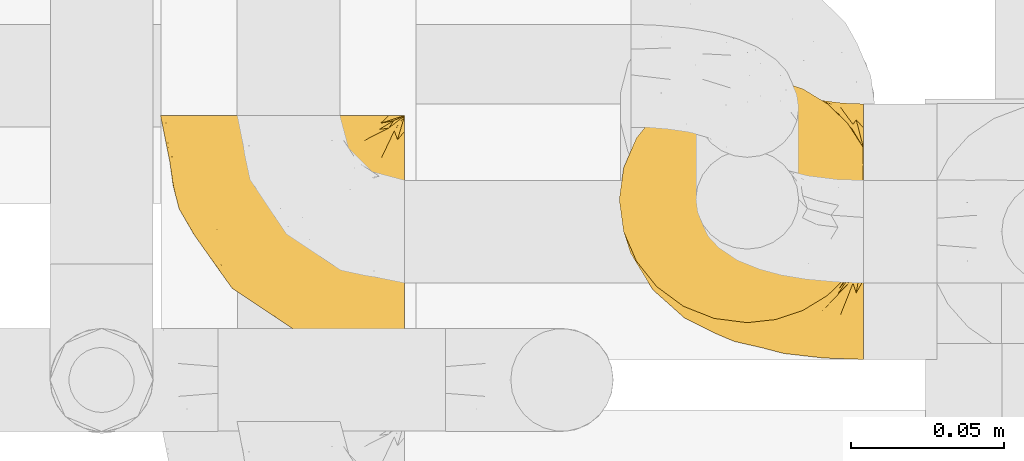
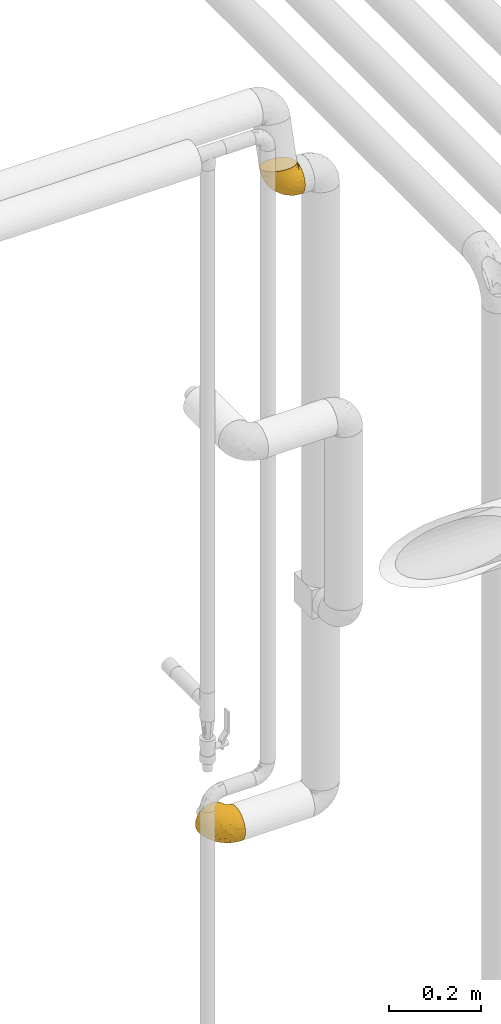
# One storey, part 354 of 827: 2 coverings.
"""IFC2X3 building model written with IfcOpenShell, lengths in millimetres."""

from ifc_helpers import new_model, entity, si_unit, converted_unit, derived_unit, direction, frame, origin, place, context, subcontext, project, spatial, faceted_brep, element, save


model = new_model("IFC2X3")

# Units and contexts
model_context = context("Model", 3, precision=0.01, world=origin(), true_north=direction((6.12303176911189e-17, 1.0)))
body_context = subcontext(model_context, "Body", "Model", "MODEL_VIEW")
ifc_project = project(units=[si_unit("LENGTHUNIT", "METRE", prefix="MILLI"), si_unit("AREAUNIT", "SQUARE_METRE"), si_unit("VOLUMEUNIT", "CUBIC_METRE"), converted_unit("PLANEANGLEUNIT", "DEGREE", entity("IfcRatioMeasure", 0.0174532925199433), si_unit("PLANEANGLEUNIT", "RADIAN"), dimensions=[0, 0, 0, 0, 0, 0, 0]), si_unit("MASSUNIT", "GRAM", prefix="KILO"), derived_unit("MASSDENSITYUNIT", [(si_unit("MASSUNIT", "GRAM", prefix="KILO"), 1), (si_unit("LENGTHUNIT", "METRE"), -3)]), derived_unit("MOMENTOFINERTIAUNIT", [(si_unit("LENGTHUNIT", "METRE"), 4)]), si_unit("TIMEUNIT", "SECOND"), si_unit("FREQUENCYUNIT", "HERTZ"), si_unit("THERMODYNAMICTEMPERATUREUNIT", "DEGREE_CELSIUS"), derived_unit("THERMALTRANSMITTANCEUNIT", [(si_unit("MASSUNIT", "GRAM", prefix="KILO"), 1), (si_unit("THERMODYNAMICTEMPERATUREUNIT", "KELVIN"), -1), (si_unit("TIMEUNIT", "SECOND"), -3)]), derived_unit("VOLUMETRICFLOWRATEUNIT", [(si_unit("LENGTHUNIT", "METRE"), 3), (si_unit("TIMEUNIT", "SECOND"), -1)]), derived_unit("MASSFLOWRATEUNIT", [(si_unit("MASSUNIT", "GRAM", prefix="KILO"), 1), (si_unit("TIMEUNIT", "SECOND"), -1)]), derived_unit("ROTATIONALFREQUENCYUNIT", [(si_unit("TIMEUNIT", "SECOND"), -1)]), si_unit("ELECTRICCURRENTUNIT", "AMPERE"), si_unit("ELECTRICVOLTAGEUNIT", "VOLT"), si_unit("POWERUNIT", "WATT"), si_unit("FORCEUNIT", "NEWTON", prefix="KILO"), si_unit("ILLUMINANCEUNIT", "LUX"), si_unit("LUMINOUSFLUXUNIT", "LUMEN"), si_unit("LUMINOUSINTENSITYUNIT", "CANDELA"), derived_unit("USERDEFINED", [(si_unit("MASSUNIT", "GRAM", prefix="KILO"), -1), (si_unit("LENGTHUNIT", "METRE"), -2), (si_unit("TIMEUNIT", "SECOND"), 3), (si_unit("LUMINOUSFLUXUNIT", "LUMEN"), 1)]), derived_unit("LINEARVELOCITYUNIT", [(si_unit("LENGTHUNIT", "METRE"), 1), (si_unit("TIMEUNIT", "SECOND"), -1)]), si_unit("PRESSUREUNIT", "PASCAL"), derived_unit("USERDEFINED", [(si_unit("LENGTHUNIT", "METRE"), -2), (si_unit("MASSUNIT", "GRAM", prefix="KILO"), 1), (si_unit("TIMEUNIT", "SECOND"), -2)]), derived_unit("LINEARFORCEUNIT", [(si_unit("MASSUNIT", "GRAM", prefix="KILO"), 1), (si_unit("LENGTHUNIT", "METRE"), 1), (si_unit("TIMEUNIT", "SECOND"), -2), (si_unit("LENGTHUNIT", "METRE"), -1)]), derived_unit("PLANARFORCEUNIT", [(si_unit("MASSUNIT", "GRAM", prefix="KILO"), 1), (si_unit("LENGTHUNIT", "METRE"), 1), (si_unit("TIMEUNIT", "SECOND"), -2), (si_unit("LENGTHUNIT", "METRE"), -2)])], contexts=[model_context])

# Site, building, storey
site_placement = place(None, origin())
site = spatial("IfcSite", under=ifc_project, at=site_placement, CompositionType="ELEMENT")
building_placement = place(site_placement, origin())
building = spatial("IfcBuilding", under=site, at=building_placement, CompositionType="ELEMENT")
storey_placement = place(building_placement, frame((0.0, 0.0, 28200.0)))
storey = spatial("IfcBuildingStorey", under=building, at=storey_placement, Name="08", CompositionType="ELEMENT", Elevation=28200.0)

# Coverings
covering_1_placement = place(storey_placement, frame((43432.77, 15237.95, 2778.82)))
element("IfcCovering", 1, at=covering_1_placement, inside=storey, Name=":ADSK_", ObjectType=":ADSK_", PredefinedType="INSULATION", context=body_context, shape_type="Brep", body=[
    faceted_brep([(81.45, 2.13, 36.31), (81.45, 4.74, 27.31), (81.45, 9.29, 19.12), (81.45, 15.54, 12.14), (81.45, 23.19, 6.73), (81.45, 31.85, 3.15), (81.45, 41.09, 1.6), (81.45, 50.45, 2.13), (81.45, 59.45, 4.74), (81.45, 67.65, 9.29), (81.45, 74.63, 15.54), (81.45, 80.04, 23.19), (81.45, 83.61, 31.85), (81.45, 85.17, 41.15), (81.45, 84.61, 50.56), (81.45, 81.96, 59.61), (81.45, 77.35, 67.83), (81.45, 71.03, 74.8), (81.45, 70.14, 75.06), (81.45, 69.26, 75.31), (81.45, 68.49, 75.53), (81.45, 67.22, 75.89), (81.45, 65.95, 76.26), (81.45, 64.68, 76.62), (81.45, 63.41, 76.99), (81.45, 62.14, 77.35), (81.45, 60.87, 77.71), (81.45, 59.6, 78.08), (81.45, 58.33, 78.44), (81.45, 57.07, 78.81), (81.45, 55.8, 79.17), (81.45, 54.53, 79.53), (81.45, 53.26, 79.9), (81.45, 51.99, 80.26), (81.45, 50.72, 80.63), (81.45, 49.84, 80.88), (81.45, 48.95, 81.13), (81.45, 48.07, 81.39), (81.45, 47.19, 81.64), (81.45, 46.3, 81.89), (81.45, 45.42, 82.15), (81.45, 44.54, 82.4), (81.45, 43.65, 82.65), (81.45, 42.77, 82.9), (81.45, 41.89, 83.16), (81.45, 41.0, 83.41), (81.45, 40.12, 83.66), (81.45, 39.24, 83.92), (81.45, 38.36, 84.17), (81.45, 37.47, 84.42), (81.45, 36.59, 84.68), (81.45, 27.52, 82.11), (81.45, 19.25, 77.57), (81.45, 12.21, 71.3), (81.45, 6.75, 63.62), (81.45, 3.15, 54.92), (81.45, 1.6, 45.67), (76.3, 78.78, 72.77), (69.67, 85.21, 70.92), (61.7, 90.06, 69.53), (52.81, 93.07, 68.67), (43.45, 94.09, 68.38), (32.61, 92.71, 68.77), (22.52, 88.7, 69.92), (13.85, 82.3, 71.75), (7.2, 73.97, 74.14), (3.02, 64.27, 76.92), (1.6, 53.86, 79.91), (3.02, 43.44, 82.9), (7.2, 33.74, 85.68), (13.85, 25.41, 88.07), (22.52, 19.02, 89.9), (32.61, 15.0, 91.05), (43.45, 13.63, 91.45), (52.81, 14.65, 91.15), (61.7, 17.66, 90.29), (69.67, 22.5, 88.9), (76.3, 28.94, 87.06), (81.27, 36.64, 84.85), (81.27, 37.52, 84.59), (81.27, 38.79, 84.23), (81.27, 39.87, 83.92), (81.27, 40.94, 83.61), (81.27, 42.02, 83.3), (81.27, 43.1, 83.0), (81.27, 44.17, 82.69), (81.27, 45.25, 82.38), (81.27, 46.32, 82.07), (81.27, 47.4, 81.76), (81.27, 48.48, 81.45), (81.27, 49.55, 81.14), (81.27, 50.63, 80.84), (81.27, 51.7, 80.53), (81.27, 52.78, 80.22), (81.27, 53.86, 79.91), (81.27, 55.13, 79.55), (81.27, 56.4, 79.18), (81.27, 57.66, 78.82), (81.27, 58.93, 78.45), (81.27, 60.2, 78.09), (81.27, 61.47, 77.73), (81.27, 62.74, 77.36), (81.27, 64.01, 77.0), (81.27, 64.89, 76.75), (81.27, 65.78, 76.49), (81.27, 66.66, 76.24), (81.27, 67.54, 75.99), (81.27, 68.43, 75.73), (81.27, 69.31, 75.48), (81.27, 70.19, 75.23), (81.27, 71.08, 74.97), (81.31, 43.6, 82.73), (81.33, 42.56, 83.01), (81.31, 60.81, 77.8), (81.32, 61.82, 77.5), (81.31, 53.29, 79.95), (81.32, 52.26, 80.24), (81.32, 36.6, 84.73), (81.32, 37.93, 84.35), (81.32, 51.19, 80.54), (81.32, 69.88, 75.19), (81.32, 50.06, 80.86), (81.32, 67.07, 76.0), (81.3, 67.99, 75.75), (81.32, 57.35, 78.78), (81.33, 44.67, 82.41), (81.31, 45.75, 82.11), (81.33, 56.36, 79.05), (81.32, 55.33, 79.35), (81.32, 54.31, 79.65), (81.32, 68.89, 75.47), (81.31, 49.06, 81.16), (81.32, 59.81, 78.08), (81.31, 63.34, 77.07), (81.32, 64.35, 76.77), (81.32, 66.08, 76.28), (81.32, 46.86, 81.79), (81.33, 47.9, 81.48), (81.32, 41.44, 83.34), (81.31, 40.37, 83.65), (81.33, 38.99, 84.04), (81.32, 71.04, 74.85), (81.36, 36.6, 84.71), (81.4, 36.59, 84.7), (81.4, 71.03, 74.82), (81.36, 71.04, 74.84), (81.29, 36.62, 84.8), (81.3, 36.61, 84.76), (81.3, 71.05, 74.89), (81.29, 71.06, 74.93), (81.35, 65.21, 76.5), (81.31, 58.38, 78.49), (58.5, 89.77, 61.93), (71.95, 84.31, 34.29), (74.57, 85.43, 46.83), (73.93, 84.07, 57.01), (78.18, 83.64, 55.49), (78.04, 78.45, 67.67), (76.23, 79.36, 68.32), (45.99, 91.47, 59.24), (74.01, 82.71, 62.07), (73.57, 81.47, 69.35), (66.66, 86.47, 65.33), (79.09, 79.98, 64.18), (73.14, 82.04, 67.1), (60.34, 88.1, 53.25), (48.54, 88.85, 50.11), (45.36, 92.12, 61.51), (67.22, 86.39, 47.63), (62.45, 85.01, 36.74), (68.67, 85.8, 56.47), (55.49, 86.93, 43.43), (77.84, 76.83, 71.54), (68.16, 85.59, 62.27), (74.31, 84.14, 33.69), (38.78, 46.66, 13.69), (62.1, 46.46, 3.96), (50.89, 33.52, 9.0), (36.91, 89.69, 56.13), (40.37, 87.12, 47.37), (27.86, 77.24, 39.14), (15.77, 70.76, 46.45), (20.13, 81.24, 54.97), (31.54, 85.33, 49.38), (28.25, 88.44, 60.24), (57.26, 72.71, 17.09), (69.99, 71.62, 13.27), (64.58, 64.27, 8.84), (50.64, 83.78, 35.42), (51.97, 56.73, 9.12), (5.72, 54.94, 55.69), (7.42, 63.76, 56.33), (66.14, 32.69, 6.08), (11.35, 74.9, 60.86), (21.64, 47.01, 27.97), (28.57, 51.69, 21.66), (55.38, 80.52, 27.64), (68.51, 78.0, 20.79), (67.48, 55.39, 4.47), (40.78, 75.79, 27.54), (41.53, 82.05, 36.06), (46.11, 69.17, 18.35), (40.32, 61.91, 16.81), (38.36, 54.55, 15.17), (11.84, 58.75, 43.77), (12.56, 50.44, 40.34), (7.67, 45.43, 50.54), (19.39, 55.75, 31.87), (24.98, 38.29, 25.64), (37.94, 35.91, 17.32), (4.64, 49.64, 65.2), (28.09, 61.32, 25.25), (23.73, 68.86, 34.4), (34.03, 69.03, 25.45), (16.33, 41.86, 38.09), (29.29, 12.82, 77.06), (5.77, 39.87, 60.03), (21.44, 26.91, 36.72), (38.8, 24.87, 19.93), (64.58, 7.37, 25.14), (67.49, 12.59, 16.74), (22.9, 15.18, 65.48), (12.54, 24.42, 69.69), (20.04, 19.94, 50.76), (57.26, 4.58, 36.61), (69.99, 3.49, 32.8), (68.51, 2.05, 42.55), (34.54, 17.83, 30.43), (38.81, 9.53, 74.25), (48.54, 8.39, 73.18), (45.99, 11.01, 82.31), (74.31, 3.68, 56.76), (5.36, 36.27, 70.79), (18.96, 18.86, 78.33), (12.79, 35.57, 44.23), (62.11, 19.89, 11.57), (33.14, 10.06, 53.04), (33.44, 10.0, 68.12), (51.98, 13.92, 21.38), (43.42, 7.37, 67.13), (48.62, 5.33, 59.13), (62.45, 4.56, 59.81), (55.49, 6.47, 66.5), (49.68, 8.97, 30.71), (55.37, 3.55, 49.71), (71.95, 3.86, 57.36), (36.37, 11.96, 82.92), (34.04, 12.13, 41.74), (44.1, 6.51, 45.72), (9.99, 30.8, 57.62), (26.41, 14.37, 51.27), (39.19, 7.49, 60.16), (58.5, 13.88, 83.69), (67.22, 9.16, 69.76), (74.57, 9.54, 68.58), (73.92, 16.08, 76.49), (73.57, 24.84, 85.59), (73.14, 23.17, 83.98), (66.19, 18.94, 86.42), (68.16, 17.6, 81.76), (77.84, 29.94, 84.99), (76.23, 26.09, 83.6), (79.08, 23.35, 80.4), (78.04, 26.5, 82.56), (77.18, 15.71, 75.21), (68.66, 14.33, 76.94), (74.0, 19.92, 80.07), (60.34, 10.69, 75.45)], [[[0, 1, 2, 3, 4, 5, 6, 7, 8, 9, 10, 11, 12, 13, 14, 15, 16, 17, 18, 19, 20, 21, 22, 23, 24, 25, 26, 27, 28, 29, 30, 31, 32, 33, 34, 35, 36, 37, 38, 39, 40, 41, 42, 43, 44, 45, 46, 47, 48, 49, 50, 51, 52, 53, 54, 55, 56]], [[57, 58, 59, 60, 61, 62, 63, 64, 65, 66, 67, 68, 69, 70, 71, 72, 73, 74, 75, 76, 77, 78, 79, 80, 81, 82, 83, 84, 85, 86, 87, 88, 89, 90, 91, 92, 93, 94, 95, 96, 97, 98, 99, 100, 101, 102, 103, 104, 105, 106, 107, 108, 109, 110]], [[111, 84, 112]], [[113, 26, 114]], [[114, 101, 100]], [[115, 93, 116]], [[79, 117, 118]], [[33, 116, 119]], [[117, 49, 118]], [[19, 18, 120]], [[119, 121, 34]], [[122, 21, 123]], [[97, 96, 124]], [[86, 125, 126]], [[116, 92, 119]], [[127, 96, 128]], [[32, 129, 115]], [[19, 120, 130]], [[121, 90, 131]], [[94, 115, 129]], [[115, 116, 32]], [[118, 49, 48]], [[113, 99, 132]], [[133, 114, 25]], [[24, 134, 133]], [[135, 22, 122]], [[136, 137, 88]], [[84, 83, 112]], [[138, 82, 139]], [[130, 20, 19]], [[118, 48, 140]], [[81, 140, 139]], [[123, 21, 20]], [[141, 120, 18]], [[139, 82, 81]], [[130, 107, 123]], [[49, 117, 142, 143, 50]], [[18, 17, 144, 145, 141]], [[79, 78, 146, 147, 117]], [[109, 141, 148, 149, 110]], [[102, 133, 134]], [[105, 135, 122]], [[118, 80, 79]], [[80, 118, 140]], [[120, 109, 108]], [[47, 46, 140, 48]], [[81, 80, 140]], [[44, 112, 138]], [[93, 115, 94]], [[46, 139, 140]], [[46, 45, 139]], [[139, 45, 138]], [[138, 112, 83]], [[85, 84, 111]], [[112, 43, 111]], [[83, 82, 138]], [[106, 122, 123]], [[105, 122, 106]], [[21, 122, 22]], [[124, 29, 28]], [[33, 32, 116]], [[128, 129, 31]], [[32, 31, 129]], [[34, 33, 119]], [[116, 93, 92]], [[129, 95, 94]], [[95, 129, 128]], [[41, 40, 125, 42]], [[119, 91, 121]], [[36, 35, 131, 37]], [[137, 131, 89]], [[121, 131, 35]], [[90, 121, 91]], [[119, 92, 91]], [[136, 126, 39]], [[125, 86, 85]], [[42, 125, 111]], [[85, 111, 125]], [[150, 23, 22]], [[130, 108, 107]], [[130, 123, 20]], [[107, 106, 123]], [[137, 37, 131]], [[136, 38, 137]], [[89, 88, 137]], [[131, 90, 89]], [[124, 151, 97]], [[40, 39, 126]], [[87, 126, 136]], [[86, 126, 87]], [[136, 88, 87]], [[40, 126, 125]], [[39, 38, 136]], [[95, 128, 96]], [[30, 128, 31]], [[29, 124, 127]], [[127, 128, 30]], [[151, 124, 28]], [[127, 30, 29]], [[127, 124, 96]], [[151, 98, 97]], [[45, 44, 138]], [[26, 113, 132]], [[113, 100, 99]], [[132, 151, 27]], [[27, 26, 132]], [[26, 25, 114]], [[100, 113, 114]], [[101, 133, 102]], [[133, 101, 114]], [[28, 27, 151]], [[132, 99, 98]], [[23, 134, 24]], [[25, 24, 133]], [[134, 23, 150]], [[135, 104, 150]], [[150, 104, 103]], [[103, 102, 134]], [[130, 120, 108]], [[109, 120, 141]], [[42, 111, 43]], [[112, 44, 43]], [[104, 135, 105]], [[134, 150, 103]], [[135, 150, 22]], [[35, 34, 121]], [[137, 38, 37]], [[98, 151, 132]], [[59, 152, 60]], [[13, 153, 154]], [[155, 156, 154]], [[157, 158, 141]], [[159, 60, 152]], [[160, 157, 155]], [[161, 162, 58]], [[58, 162, 59]], [[144, 16, 163]], [[58, 57, 161]], [[162, 161, 164]], [[157, 163, 155]], [[163, 16, 15]], [[57, 149, 161]], [[152, 165, 166]], [[157, 144, 163]], [[60, 159, 167, 61]], [[156, 14, 154]], [[163, 156, 155]], [[155, 154, 168]], [[168, 154, 169]], [[155, 170, 160]], [[57, 110, 149]], [[144, 17, 16]], [[156, 15, 14]], [[171, 165, 168]], [[158, 164, 172]], [[14, 13, 154]], [[157, 141, 145, 144]], [[173, 164, 158]], [[173, 160, 170]], [[171, 166, 165]], [[168, 165, 170]], [[168, 169, 171]], [[152, 173, 165]], [[170, 155, 168]], [[165, 173, 170]], [[160, 173, 158]], [[172, 149, 148]], [[148, 141, 158]], [[158, 157, 160]], [[152, 166, 159]], [[173, 152, 162]], [[59, 162, 152]], [[13, 12, 174, 153]], [[153, 169, 154]], [[15, 156, 163]], [[162, 164, 173]], [[172, 164, 161]], [[149, 172, 161]], [[158, 172, 148]], [[175, 176, 177]], [[178, 166, 179]], [[180, 181, 182]], [[183, 184, 178]], [[185, 186, 187]], [[171, 188, 179]], [[174, 12, 11]], [[189, 176, 175]], [[190, 66, 191]], [[176, 6, 192]], [[193, 65, 64]], [[63, 184, 182]], [[63, 182, 64]], [[65, 193, 191]], [[184, 63, 62]], [[175, 194, 195]], [[196, 169, 197]], [[174, 11, 197]], [[8, 7, 198]], [[187, 9, 8]], [[197, 169, 153, 174]], [[197, 11, 10]], [[186, 197, 10]], [[199, 180, 200]], [[197, 185, 196]], [[201, 189, 202]], [[201, 187, 189]], [[195, 203, 175]], [[191, 204, 190]], [[176, 7, 6]], [[177, 176, 192]], [[189, 198, 176]], [[65, 191, 66]], [[198, 187, 8]], [[205, 206, 190]], [[9, 186, 10]], [[181, 207, 204]], [[208, 175, 177, 209]], [[66, 190, 210]], [[211, 212, 213]], [[190, 204, 205]], [[180, 182, 183]], [[193, 182, 181]], [[62, 61, 167]], [[196, 185, 199]], [[196, 200, 188]], [[6, 5, 192]], [[176, 198, 7]], [[187, 198, 189]], [[187, 186, 9]], [[197, 186, 185]], [[200, 180, 183]], [[180, 213, 212]], [[179, 183, 178]], [[185, 201, 199]], [[210, 190, 206]], [[210, 67, 66]], [[205, 204, 207]], [[194, 205, 207]], [[194, 214, 205]], [[195, 194, 207]], [[208, 194, 175]], [[207, 211, 195]], [[202, 203, 211]], [[212, 207, 181]], [[202, 211, 213]], [[201, 202, 213]], [[189, 175, 203]], [[199, 201, 213]], [[187, 201, 185]], [[180, 199, 213]], [[196, 199, 200]], [[211, 203, 195]], [[189, 203, 202]], [[207, 212, 211]], [[180, 212, 181]], [[214, 194, 208]], [[214, 206, 205]], [[196, 188, 169]], [[181, 204, 191]], [[182, 193, 64]], [[191, 193, 181]], [[178, 62, 167]], [[182, 184, 183]], [[62, 178, 184]], [[178, 167, 159, 166]], [[171, 179, 166]], [[200, 183, 179]], [[179, 188, 200]], [[169, 188, 171]], [[71, 215, 72]], [[206, 216, 210]], [[217, 208, 218]], [[216, 68, 210]], [[219, 220, 2]], [[221, 222, 223]], [[224, 225, 226]], [[227, 223, 217]], [[228, 229, 230]], [[56, 231, 226]], [[232, 222, 69]], [[56, 55, 231]], [[70, 233, 71]], [[71, 233, 215]], [[0, 56, 226]], [[208, 217, 234]], [[218, 177, 235]], [[221, 236, 237]], [[238, 220, 219]], [[1, 219, 2]], [[68, 216, 232]], [[235, 3, 220]], [[235, 192, 4]], [[1, 0, 225]], [[228, 239, 229]], [[240, 241, 242]], [[243, 238, 219]], [[224, 226, 244]], [[226, 241, 244]], [[3, 235, 4]], [[69, 222, 70]], [[225, 219, 1]], [[218, 235, 238]], [[243, 219, 224]], [[218, 227, 217]], [[3, 2, 220]], [[218, 208, 209, 177]], [[226, 231, 245, 241]], [[215, 228, 246]], [[247, 248, 236]], [[248, 224, 244]], [[223, 222, 249]], [[233, 222, 221]], [[242, 239, 240]], [[248, 247, 243]], [[217, 223, 249]], [[250, 247, 236]], [[216, 234, 249]], [[218, 238, 227]], [[192, 235, 177]], [[192, 5, 4]], [[72, 246, 73]], [[235, 220, 238]], [[226, 225, 0]], [[219, 225, 224]], [[240, 248, 244]], [[239, 242, 229]], [[236, 248, 251]], [[68, 67, 210]], [[234, 216, 206]], [[216, 249, 232]], [[234, 206, 214, 208]], [[249, 234, 217]], [[222, 232, 249]], [[69, 68, 232]], [[246, 228, 230]], [[237, 228, 215]], [[243, 227, 238]], [[223, 227, 247]], [[73, 246, 230]], [[215, 246, 72]], [[248, 243, 224]], [[227, 243, 247]], [[237, 236, 251]], [[250, 221, 223]], [[222, 233, 70]], [[215, 233, 221]], [[221, 237, 215]], [[239, 237, 251]], [[237, 239, 228]], [[239, 251, 240]], [[248, 240, 251]], [[241, 240, 244]], [[221, 250, 236]], [[223, 247, 250]], [[74, 230, 252]], [[253, 254, 255]], [[146, 77, 256]], [[257, 258, 259]], [[260, 256, 257]], [[260, 261, 147]], [[75, 74, 252]], [[51, 143, 262]], [[263, 143, 142, 117]], [[256, 77, 76]], [[252, 258, 75]], [[253, 241, 254]], [[254, 245, 54]], [[258, 256, 76]], [[53, 52, 264]], [[255, 265, 253]], [[254, 264, 255]], [[255, 264, 262]], [[75, 258, 76]], [[265, 255, 266]], [[255, 262, 263]], [[51, 50, 143]], [[54, 245, 231, 55]], [[51, 262, 52]], [[253, 267, 242]], [[254, 54, 53]], [[266, 259, 265]], [[146, 78, 77]], [[263, 117, 261]], [[146, 256, 260]], [[257, 259, 261]], [[267, 253, 265]], [[229, 267, 252]], [[242, 267, 229]], [[242, 241, 253]], [[252, 267, 259]], [[255, 263, 266]], [[259, 267, 265]], [[261, 117, 147]], [[263, 261, 266]], [[259, 266, 261]], [[230, 74, 73]], [[230, 229, 252]], [[259, 258, 252]], [[254, 241, 245]], [[53, 264, 254]], [[52, 262, 264]], [[143, 263, 262]], [[258, 257, 256]], [[261, 260, 257]], [[146, 260, 147]]]),
])
covering_2_placement = place(storey_placement, frame((43282.77, 15237.88, 1117.26)))
element("IfcCovering", 2, at=covering_2_placement, inside=storey, Name=":ADSK_", ObjectType=":ADSK_", PredefinedType="INSULATION", context=body_context, shape_type="Brep", body=[
    faceted_brep([(81.45, 25.28, 81.15), (81.45, 17.35, 76.16), (81.45, 10.72, 69.53), (81.45, 5.74, 61.6), (81.45, 2.64, 52.75), (81.45, 1.6, 43.45), (81.45, 2.65, 34.13), (81.45, 5.74, 25.28), (81.45, 10.73, 17.35), (81.45, 17.36, 10.72), (81.45, 25.29, 5.74), (81.45, 34.14, 2.64), (81.45, 43.45, 1.6), (81.45, 52.82, 2.66), (81.45, 61.71, 5.79), (81.45, 69.67, 10.83), (81.45, 76.31, 17.53), (81.45, 81.27, 25.53), (81.45, 81.27, 26.45), (81.45, 81.27, 27.37), (81.45, 81.27, 28.17), (81.45, 81.27, 29.49), (81.45, 81.27, 30.81), (81.45, 81.27, 32.13), (81.45, 81.27, 33.45), (81.45, 81.27, 34.78), (81.45, 81.27, 36.1), (81.45, 81.27, 37.42), (81.45, 81.27, 38.74), (81.45, 81.27, 40.06), (81.45, 81.27, 41.38), (81.45, 81.27, 42.7), (81.45, 81.27, 44.02), (81.45, 81.27, 45.34), (81.45, 81.27, 46.66), (81.45, 81.27, 47.58), (81.45, 81.27, 48.5), (81.45, 81.27, 49.41), (81.45, 81.27, 50.33), (81.45, 81.27, 51.25), (81.45, 81.27, 52.17), (81.45, 81.27, 53.09), (81.45, 81.27, 54.01), (81.45, 81.27, 54.93), (81.45, 81.27, 55.85), (81.45, 81.27, 56.76), (81.45, 81.27, 57.68), (81.45, 81.27, 58.6), (81.45, 81.27, 59.52), (81.45, 81.27, 60.44), (81.45, 81.27, 61.36), (81.45, 76.3, 69.37), (81.45, 69.66, 76.07), (81.45, 61.69, 81.11), (81.45, 52.8, 84.24), (81.45, 43.45, 85.3), (81.45, 34.13, 84.24), (76.3, 81.45, 17.52), (69.67, 81.45, 10.83), (61.7, 81.45, 5.79), (52.81, 81.45, 2.66), (43.45, 81.45, 1.6), (32.61, 81.45, 3.02), (22.52, 81.45, 7.2), (13.85, 81.45, 13.85), (7.2, 81.45, 22.52), (3.02, 81.45, 32.61), (1.6, 81.45, 43.45), (3.02, 81.45, 54.28), (7.2, 81.45, 64.37), (13.85, 81.45, 73.04), (22.52, 81.45, 79.69), (32.61, 81.45, 83.87), (43.45, 81.45, 85.3), (52.81, 81.45, 84.23), (61.7, 81.45, 81.1), (69.67, 81.45, 76.06), (76.3, 81.45, 69.37), (81.27, 81.45, 61.36), (81.27, 81.45, 60.44), (81.27, 81.45, 59.12), (81.27, 81.45, 58.0), (81.27, 81.45, 56.88), (81.27, 81.45, 55.76), (81.27, 81.45, 54.64), (81.27, 81.45, 53.52), (81.27, 81.45, 52.4), (81.27, 81.45, 51.28), (81.27, 81.45, 50.16), (81.27, 81.45, 49.04), (81.27, 81.45, 47.92), (81.27, 81.45, 46.8), (81.27, 81.45, 45.68), (81.27, 81.45, 44.56), (81.27, 81.45, 43.45), (81.27, 81.45, 42.12), (81.27, 81.45, 40.8), (81.27, 81.45, 39.48), (81.27, 81.45, 38.16), (81.27, 81.45, 36.84), (81.27, 81.45, 35.52), (81.27, 81.45, 34.2), (81.27, 81.45, 32.88), (81.27, 81.45, 31.96), (81.27, 81.45, 31.05), (81.27, 81.45, 30.13), (81.27, 81.45, 29.21), (81.27, 81.45, 28.29), (81.27, 81.45, 27.37), (81.27, 81.45, 26.45), (81.27, 81.45, 25.53), (81.31, 81.33, 54.08), (81.33, 81.32, 55.16), (81.31, 81.33, 36.18), (81.32, 81.32, 35.13), (81.31, 81.33, 44.01), (81.32, 81.32, 45.08), (81.32, 81.32, 61.36), (81.32, 81.32, 59.98), (81.32, 81.32, 46.18), (81.32, 81.32, 26.74), (81.32, 81.32, 47.36), (81.32, 81.32, 29.67), (81.3, 81.34, 28.72), (81.32, 81.32, 39.77), (81.33, 81.31, 52.96), (81.31, 81.33, 51.84), (81.33, 81.31, 40.8), (81.32, 81.32, 41.87), (81.32, 81.33, 42.94), (81.32, 81.32, 27.77), (81.31, 81.33, 48.4), (81.32, 81.32, 37.21), (81.31, 81.33, 33.54), (81.32, 81.32, 32.49), (81.32, 81.32, 30.69), (81.32, 81.32, 50.69), (81.33, 81.31, 49.6), (81.32, 81.32, 56.32), (81.31, 81.33, 57.44), (81.33, 81.31, 58.88), (81.32, 81.32, 25.53), (81.36, 81.3, 61.36), (81.4, 81.29, 61.36), (81.4, 81.29, 25.53), (81.36, 81.3, 25.53), (81.29, 81.4, 61.36), (81.3, 81.36, 61.36), (81.3, 81.36, 25.53), (81.29, 81.4, 25.53), (81.35, 81.3, 31.59), (81.31, 81.33, 38.71), (58.5, 74.06, 3.97), (71.95, 45.99, 1.6), (74.57, 58.35, 3.97), (73.93, 67.76, 8.09), (78.18, 66.18, 8.09), (78.04, 76.46, 16.43), (76.23, 77.33, 15.73), (45.99, 71.95, 1.6), (74.01, 72.25, 10.79), (73.57, 78.91, 13.99), (66.66, 76.42, 8.08), (79.09, 73.52, 14.0), (73.14, 76.9, 12.83), (60.34, 65.25, 3.18), (48.54, 62.45, 1.6), (45.36, 74.31, 1.6), (67.22, 59.38, 3.28), (62.45, 48.54, 1.6), (68.67, 67.72, 6.28), (55.49, 55.49, 1.6), (77.84, 79.73, 19.06), (68.16, 73.23, 8.08), (74.31, 45.36, 1.6), (38.78, 15.81, 32.11), (62.1, 6.4, 29.62), (50.89, 7.67, 43.45), (36.91, 68.46, 2.45), (40.37, 59.33, 2.5), (27.86, 48.7, 9.73), (15.77, 53.94, 17.97), (20.13, 65.02, 10.24), (31.54, 60.77, 4.78), (28.25, 72.07, 4.78), (57.26, 26.25, 8.01), (69.99, 22.29, 8.01), (64.58, 16.0, 13.85), (50.64, 46.93, 2.42), (51.97, 14.19, 21.17), (5.72, 58.46, 35.73), (7.42, 61.51, 27.43), (66.14, 4.64, 43.45), (11.35, 68.93, 17.97), (21.64, 29.62, 35.71), (28.57, 24.85, 29.47), (55.38, 38.55, 3.41), (68.51, 31.27, 3.94), (67.48, 9.35, 21.17), (40.78, 37.15, 7.92), (41.53, 47.07, 4.25), (46.11, 26.49, 11.75), (40.32, 23.01, 18.31), (38.36, 19.4, 24.94), (11.84, 48.06, 28.78), (12.56, 42.46, 35.82), (7.67, 50.89, 43.45), (19.39, 35.78, 28.38), (24.98, 24.98, 43.45), (37.94, 16.33, 43.45), (4.64, 66.14, 43.45), (28.09, 30.96, 21.21), (23.73, 41.83, 16.48), (34.03, 33.28, 13.85), (16.33, 37.94, 43.45), (29.29, 67.39, 82.11), (5.77, 58.47, 51.41), (21.44, 32.5, 57.45), (38.8, 15.79, 54.78), (64.58, 15.99, 73.03), (67.49, 9.34, 65.7), (22.9, 56.91, 76.65), (12.54, 63.5, 68.92), (20.04, 44.08, 68.01), (57.26, 26.24, 78.88), (69.99, 22.27, 78.88), (68.51, 31.26, 82.94), (34.54, 23.95, 64.44), (38.81, 63.79, 84.49), (48.54, 62.45, 85.3), (45.99, 71.95, 85.3), (74.31, 45.36, 85.3), (5.36, 67.83, 57.84), (18.96, 70.28, 76.65), (12.79, 42.11, 51.19), (62.11, 6.39, 57.26), (33.14, 43.54, 78.14), (33.44, 58.03, 82.35), (51.98, 14.18, 65.7), (43.42, 56.34, 84.61), (48.62, 48.09, 84.36), (62.45, 48.54, 85.3), (55.49, 55.49, 85.3), (49.68, 21.78, 73.03), (55.37, 38.54, 83.48), (71.95, 45.99, 85.3), (36.37, 72.79, 84.54), (34.04, 33.26, 73.03), (44.1, 35.53, 79.54), (9.99, 53.66, 59.46), (26.41, 43.03, 73.5), (39.19, 49.68, 82.57), (58.5, 74.06, 82.92), (67.22, 59.37, 83.62), (74.57, 58.34, 82.92), (73.92, 67.75, 78.81), (73.57, 78.91, 72.9), (73.14, 76.9, 74.06), (66.19, 78.08, 78.81), (68.16, 73.23, 78.81), (77.84, 79.73, 67.83), (76.23, 77.34, 71.15), (79.08, 73.51, 72.91), (78.04, 76.45, 70.47), (77.18, 66.41, 78.81), (68.66, 67.7, 80.62), (74.0, 72.24, 76.11), (60.34, 65.25, 83.71)], [[[0, 1, 2, 3, 4, 5, 6, 7, 8, 9, 10, 11, 12, 13, 14, 15, 16, 17, 18, 19, 20, 21, 22, 23, 24, 25, 26, 27, 28, 29, 30, 31, 32, 33, 34, 35, 36, 37, 38, 39, 40, 41, 42, 43, 44, 45, 46, 47, 48, 49, 50, 51, 52, 53, 54, 55, 56]], [[57, 58, 59, 60, 61, 62, 63, 64, 65, 66, 67, 68, 69, 70, 71, 72, 73, 74, 75, 76, 77, 78, 79, 80, 81, 82, 83, 84, 85, 86, 87, 88, 89, 90, 91, 92, 93, 94, 95, 96, 97, 98, 99, 100, 101, 102, 103, 104, 105, 106, 107, 108, 109, 110]], [[111, 84, 112]], [[113, 26, 114]], [[114, 101, 100]], [[115, 93, 116]], [[79, 117, 118]], [[33, 116, 119]], [[117, 49, 118]], [[19, 18, 120]], [[119, 121, 34]], [[122, 21, 123]], [[97, 96, 124]], [[86, 125, 126]], [[116, 92, 119]], [[127, 96, 128]], [[32, 129, 115]], [[19, 120, 130]], [[121, 90, 131]], [[94, 115, 129]], [[115, 116, 32]], [[118, 49, 48]], [[113, 99, 132]], [[133, 114, 25]], [[24, 134, 133]], [[135, 22, 122]], [[136, 137, 88]], [[84, 83, 112]], [[138, 82, 139]], [[130, 20, 19]], [[118, 48, 140]], [[81, 140, 139]], [[123, 21, 20]], [[141, 120, 18]], [[139, 82, 81]], [[130, 107, 123]], [[49, 117, 142, 143, 50]], [[18, 17, 144, 145, 141]], [[79, 78, 146, 147, 117]], [[109, 141, 148, 149, 110]], [[102, 133, 134]], [[105, 135, 122]], [[118, 80, 79]], [[80, 118, 140]], [[120, 109, 108]], [[47, 46, 140, 48]], [[81, 80, 140]], [[44, 112, 138]], [[93, 115, 94]], [[46, 139, 140]], [[46, 45, 139]], [[139, 45, 138]], [[138, 112, 83]], [[85, 84, 111]], [[112, 43, 111]], [[83, 82, 138]], [[106, 122, 123]], [[105, 122, 106]], [[21, 122, 22]], [[124, 29, 28]], [[33, 32, 116]], [[128, 129, 31]], [[32, 31, 129]], [[34, 33, 119]], [[116, 93, 92]], [[129, 95, 94]], [[95, 129, 128]], [[41, 40, 125, 42]], [[119, 91, 121]], [[36, 35, 131, 37]], [[137, 131, 89]], [[121, 131, 35]], [[90, 121, 91]], [[119, 92, 91]], [[136, 126, 39]], [[125, 86, 85]], [[42, 125, 111]], [[85, 111, 125]], [[150, 23, 22]], [[130, 108, 107]], [[130, 123, 20]], [[107, 106, 123]], [[137, 37, 131]], [[136, 38, 137]], [[89, 88, 137]], [[131, 90, 89]], [[124, 151, 97]], [[40, 39, 126]], [[87, 126, 136]], [[86, 126, 87]], [[136, 88, 87]], [[40, 126, 125]], [[39, 38, 136]], [[95, 128, 96]], [[30, 128, 31]], [[29, 124, 127]], [[127, 128, 30]], [[151, 124, 28]], [[127, 30, 29]], [[127, 124, 96]], [[151, 98, 97]], [[45, 44, 138]], [[26, 113, 132]], [[113, 100, 99]], [[132, 151, 27]], [[27, 26, 132]], [[26, 25, 114]], [[100, 113, 114]], [[101, 133, 102]], [[133, 101, 114]], [[28, 27, 151]], [[132, 99, 98]], [[23, 134, 24]], [[25, 24, 133]], [[134, 23, 150]], [[135, 104, 150]], [[150, 104, 103]], [[103, 102, 134]], [[130, 120, 108]], [[109, 120, 141]], [[42, 111, 43]], [[112, 44, 43]], [[104, 135, 105]], [[134, 150, 103]], [[135, 150, 22]], [[35, 34, 121]], [[137, 38, 37]], [[98, 151, 132]], [[59, 152, 60]], [[13, 153, 154]], [[155, 156, 154]], [[157, 158, 141]], [[159, 60, 152]], [[160, 157, 155]], [[161, 162, 58]], [[58, 162, 59]], [[144, 16, 163]], [[58, 57, 161]], [[162, 161, 164]], [[157, 163, 155]], [[163, 16, 15]], [[57, 149, 161]], [[152, 165, 166]], [[157, 144, 163]], [[60, 159, 167, 61]], [[156, 14, 154]], [[163, 156, 155]], [[155, 154, 168]], [[168, 154, 169]], [[155, 170, 160]], [[57, 110, 149]], [[144, 17, 16]], [[156, 15, 14]], [[171, 165, 168]], [[158, 164, 172]], [[14, 13, 154]], [[157, 141, 145, 144]], [[173, 164, 158]], [[173, 160, 170]], [[171, 166, 165]], [[168, 165, 170]], [[168, 169, 171]], [[152, 173, 165]], [[170, 155, 168]], [[165, 173, 170]], [[160, 173, 158]], [[172, 149, 148]], [[148, 141, 158]], [[158, 157, 160]], [[152, 166, 159]], [[173, 152, 162]], [[59, 162, 152]], [[13, 12, 174, 153]], [[153, 169, 154]], [[15, 156, 163]], [[162, 164, 173]], [[172, 164, 161]], [[149, 172, 161]], [[158, 172, 148]], [[175, 176, 177]], [[178, 166, 179]], [[180, 181, 182]], [[183, 184, 178]], [[185, 186, 187]], [[171, 188, 179]], [[174, 12, 11]], [[189, 176, 175]], [[190, 66, 191]], [[176, 6, 192]], [[193, 65, 64]], [[63, 184, 182]], [[63, 182, 64]], [[65, 193, 191]], [[184, 63, 62]], [[175, 194, 195]], [[196, 169, 197]], [[174, 11, 197]], [[8, 7, 198]], [[187, 9, 8]], [[197, 169, 153, 174]], [[197, 11, 10]], [[186, 197, 10]], [[199, 180, 200]], [[197, 185, 196]], [[201, 189, 202]], [[201, 187, 189]], [[195, 203, 175]], [[191, 204, 190]], [[176, 7, 6]], [[177, 176, 192]], [[189, 198, 176]], [[65, 191, 66]], [[198, 187, 8]], [[205, 206, 190]], [[9, 186, 10]], [[181, 207, 204]], [[208, 175, 177, 209]], [[66, 190, 210]], [[211, 212, 213]], [[190, 204, 205]], [[180, 182, 183]], [[193, 182, 181]], [[62, 61, 167]], [[196, 185, 199]], [[196, 200, 188]], [[6, 5, 192]], [[176, 198, 7]], [[187, 198, 189]], [[187, 186, 9]], [[197, 186, 185]], [[200, 180, 183]], [[180, 213, 212]], [[179, 183, 178]], [[185, 201, 199]], [[210, 190, 206]], [[210, 67, 66]], [[205, 204, 207]], [[194, 205, 207]], [[194, 214, 205]], [[195, 194, 207]], [[208, 194, 175]], [[207, 211, 195]], [[202, 203, 211]], [[212, 207, 181]], [[202, 211, 213]], [[201, 202, 213]], [[189, 175, 203]], [[199, 201, 213]], [[187, 201, 185]], [[180, 199, 213]], [[196, 199, 200]], [[211, 203, 195]], [[189, 203, 202]], [[207, 212, 211]], [[180, 212, 181]], [[214, 194, 208]], [[214, 206, 205]], [[196, 188, 169]], [[181, 204, 191]], [[182, 193, 64]], [[191, 193, 181]], [[178, 62, 167]], [[182, 184, 183]], [[62, 178, 184]], [[178, 167, 159, 166]], [[171, 179, 166]], [[200, 183, 179]], [[179, 188, 200]], [[169, 188, 171]], [[71, 215, 72]], [[206, 216, 210]], [[217, 208, 218]], [[216, 68, 210]], [[219, 220, 2]], [[221, 222, 223]], [[224, 225, 226]], [[227, 223, 217]], [[228, 229, 230]], [[56, 231, 226]], [[232, 222, 69]], [[56, 55, 231]], [[70, 233, 71]], [[71, 233, 215]], [[0, 56, 226]], [[208, 217, 234]], [[218, 177, 235]], [[221, 236, 237]], [[238, 220, 219]], [[1, 219, 2]], [[68, 216, 232]], [[235, 3, 220]], [[235, 192, 4]], [[1, 0, 225]], [[228, 239, 229]], [[240, 241, 242]], [[243, 238, 219]], [[224, 226, 244]], [[226, 241, 244]], [[3, 235, 4]], [[69, 222, 70]], [[225, 219, 1]], [[218, 235, 238]], [[243, 219, 224]], [[218, 227, 217]], [[3, 2, 220]], [[218, 208, 209, 177]], [[226, 231, 245, 241]], [[215, 228, 246]], [[247, 248, 236]], [[248, 224, 244]], [[223, 222, 249]], [[233, 222, 221]], [[242, 239, 240]], [[248, 247, 243]], [[217, 223, 249]], [[250, 247, 236]], [[216, 234, 249]], [[218, 238, 227]], [[192, 235, 177]], [[192, 5, 4]], [[72, 246, 73]], [[235, 220, 238]], [[226, 225, 0]], [[219, 225, 224]], [[240, 248, 244]], [[239, 242, 229]], [[236, 248, 251]], [[68, 67, 210]], [[234, 216, 206]], [[216, 249, 232]], [[234, 206, 214, 208]], [[249, 234, 217]], [[222, 232, 249]], [[69, 68, 232]], [[246, 228, 230]], [[237, 228, 215]], [[243, 227, 238]], [[223, 227, 247]], [[73, 246, 230]], [[215, 246, 72]], [[248, 243, 224]], [[227, 243, 247]], [[237, 236, 251]], [[250, 221, 223]], [[222, 233, 70]], [[215, 233, 221]], [[221, 237, 215]], [[239, 237, 251]], [[237, 239, 228]], [[239, 251, 240]], [[248, 240, 251]], [[241, 240, 244]], [[221, 250, 236]], [[223, 247, 250]], [[74, 230, 252]], [[253, 254, 255]], [[146, 77, 256]], [[257, 258, 259]], [[260, 256, 257]], [[260, 261, 147]], [[75, 74, 252]], [[51, 143, 262]], [[263, 143, 142, 117]], [[256, 77, 76]], [[252, 258, 75]], [[253, 241, 254]], [[254, 245, 54]], [[258, 256, 76]], [[53, 52, 264]], [[255, 265, 253]], [[254, 264, 255]], [[255, 264, 262]], [[75, 258, 76]], [[265, 255, 266]], [[255, 262, 263]], [[51, 50, 143]], [[54, 245, 231, 55]], [[51, 262, 52]], [[253, 267, 242]], [[254, 54, 53]], [[266, 259, 265]], [[146, 78, 77]], [[263, 117, 261]], [[146, 256, 260]], [[257, 259, 261]], [[267, 253, 265]], [[229, 267, 252]], [[242, 267, 229]], [[242, 241, 253]], [[252, 267, 259]], [[255, 263, 266]], [[259, 267, 265]], [[261, 117, 147]], [[263, 261, 266]], [[259, 266, 261]], [[230, 74, 73]], [[230, 229, 252]], [[259, 258, 252]], [[254, 241, 245]], [[53, 264, 254]], [[52, 262, 264]], [[143, 263, 262]], [[258, 257, 256]], [[261, 260, 257]], [[146, 260, 147]]]),
])

save(model, "model.ifc")
